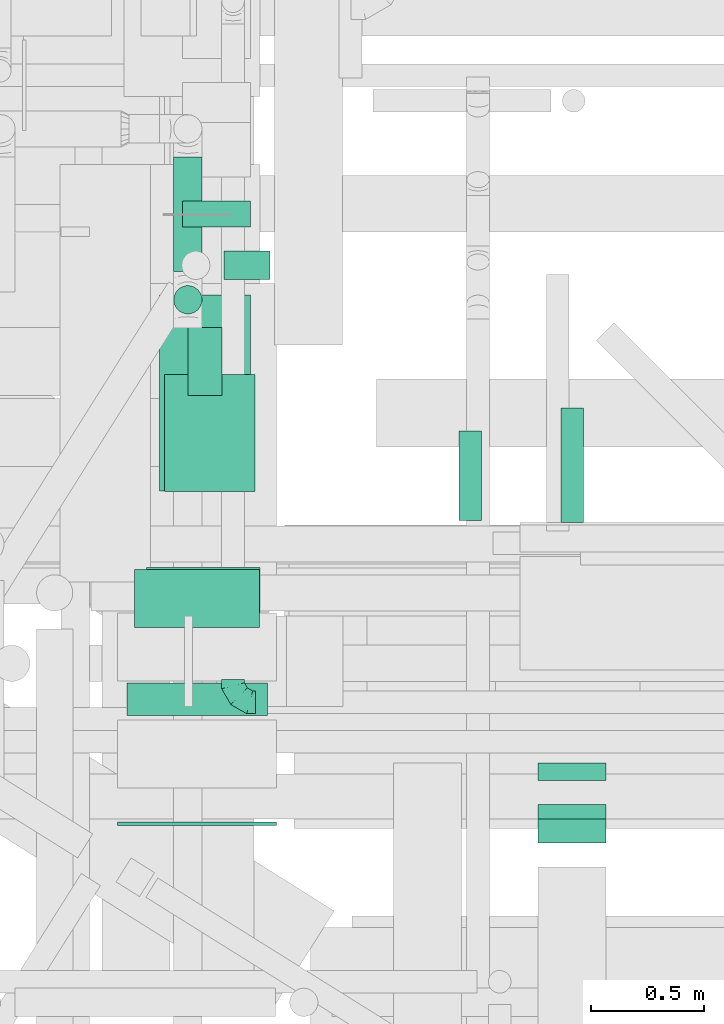
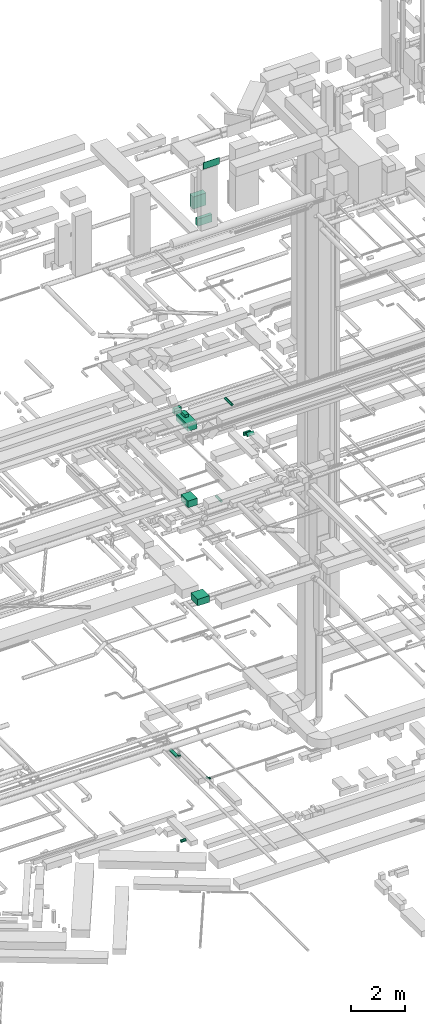
# One storey, part 104 of 337: 15 flow segments, 1 flow fitting.
"""IFC2X3 building model written with IfcOpenShell, lengths in millimetres."""

from ifc_helpers import new_model, entity, si_unit, converted_unit, derived_unit, direction, frame, origin, origin_2d_with_axis, place, context, subcontext, project, spatial, rectangle, circle, extrude, faceted_brep, source, transform, mapped, material, type_object, type_shapes, element, save


model = new_model("IFC2X3")

# Units and contexts
model_context = context("Model", 3, precision=0.01, world=origin(), true_north=direction((6.12303176911189e-17, 1.0)))
body_context = subcontext(model_context, "Body", "Model", "MODEL_VIEW")
ifc_project = project(units=[si_unit("LENGTHUNIT", "METRE", prefix="MILLI"), si_unit("AREAUNIT", "SQUARE_METRE"), si_unit("VOLUMEUNIT", "CUBIC_METRE"), converted_unit("PLANEANGLEUNIT", "DEGREE", entity("IfcRatioMeasure", 0.0174532925199433), si_unit("PLANEANGLEUNIT", "RADIAN"), dimensions=[0, 0, 0, 0, 0, 0, 0]), si_unit("MASSUNIT", "GRAM", prefix="KILO"), derived_unit("MASSDENSITYUNIT", [(si_unit("MASSUNIT", "GRAM", prefix="KILO"), 1), (si_unit("LENGTHUNIT", "METRE"), -3)]), derived_unit("MOMENTOFINERTIAUNIT", [(si_unit("LENGTHUNIT", "METRE"), 4)]), si_unit("TIMEUNIT", "SECOND"), si_unit("FREQUENCYUNIT", "HERTZ"), si_unit("THERMODYNAMICTEMPERATUREUNIT", "DEGREE_CELSIUS"), derived_unit("THERMALTRANSMITTANCEUNIT", [(si_unit("MASSUNIT", "GRAM", prefix="KILO"), 1), (si_unit("THERMODYNAMICTEMPERATUREUNIT", "KELVIN"), -1), (si_unit("TIMEUNIT", "SECOND"), -3)]), derived_unit("VOLUMETRICFLOWRATEUNIT", [(si_unit("LENGTHUNIT", "METRE"), 3), (si_unit("TIMEUNIT", "SECOND"), -1)]), derived_unit("MASSFLOWRATEUNIT", [(si_unit("MASSUNIT", "GRAM", prefix="KILO"), 1), (si_unit("TIMEUNIT", "SECOND"), -1)]), derived_unit("ROTATIONALFREQUENCYUNIT", [(si_unit("TIMEUNIT", "SECOND"), -1)]), si_unit("ELECTRICCURRENTUNIT", "AMPERE"), si_unit("ELECTRICVOLTAGEUNIT", "VOLT"), si_unit("POWERUNIT", "WATT"), si_unit("FORCEUNIT", "NEWTON", prefix="KILO"), si_unit("ILLUMINANCEUNIT", "LUX"), si_unit("LUMINOUSFLUXUNIT", "LUMEN"), si_unit("LUMINOUSINTENSITYUNIT", "CANDELA"), derived_unit("USERDEFINED", [(si_unit("MASSUNIT", "GRAM", prefix="KILO"), -1), (si_unit("LENGTHUNIT", "METRE"), -2), (si_unit("TIMEUNIT", "SECOND"), 3), (si_unit("LUMINOUSFLUXUNIT", "LUMEN"), 1)]), derived_unit("LINEARVELOCITYUNIT", [(si_unit("LENGTHUNIT", "METRE"), 1), (si_unit("TIMEUNIT", "SECOND"), -1)]), si_unit("PRESSUREUNIT", "PASCAL"), derived_unit("USERDEFINED", [(si_unit("LENGTHUNIT", "METRE"), -2), (si_unit("MASSUNIT", "GRAM", prefix="KILO"), 1), (si_unit("TIMEUNIT", "SECOND"), -2)]), derived_unit("LINEARFORCEUNIT", [(si_unit("MASSUNIT", "GRAM", prefix="KILO"), 1), (si_unit("LENGTHUNIT", "METRE"), 1), (si_unit("TIMEUNIT", "SECOND"), -2), (si_unit("LENGTHUNIT", "METRE"), -1)]), derived_unit("PLANARFORCEUNIT", [(si_unit("MASSUNIT", "GRAM", prefix="KILO"), 1), (si_unit("LENGTHUNIT", "METRE"), 1), (si_unit("TIMEUNIT", "SECOND"), -2), (si_unit("LENGTHUNIT", "METRE"), -2)])], contexts=[model_context])

# Site, building, storey
site_placement = place(None, origin())
site = spatial("IfcSite", under=ifc_project, at=site_placement, CompositionType="ELEMENT")
building_placement = place(site_placement, origin())
building = spatial("IfcBuilding", under=site, at=building_placement, CompositionType="ELEMENT")
storey_placement = place(building_placement, origin())
storey = spatial("IfcBuildingStorey", under=building, at=storey_placement, CompositionType="ELEMENT", Elevation=0.0)

# Flow segments
duct_segment_type_1 = type_object("IfcDuctSegmentType", PredefinedType="NOTDEFINED")
flow_segment_1_placement = place(storey_placement, frame((18241.81, 9637.88, 11250.0)))
element("IfcFlowSegment", 1, at=flow_segment_1_placement, inside=storey, type_object=duct_segment_type_1, context=body_context, shape_type="SweptSolid", body=[
    extrude(rectangle(XDim=499.999999999994, YDim=500.000000000001, at=origin_2d_with_axis()), frame((250.0, 250.0, 0.0), z_axis=(0.0, 0.0, 1.0), x_axis=(0.0, 1.0, 0.0)), (0.0, 0.0, 1.0), 300.000000000001),
])
flow_segment_2_placement = place(storey_placement, frame((18320.0, 10474.94, 15150.0)))
element("IfcFlowSegment", 2, at=flow_segment_2_placement, inside=storey, type_object=duct_segment_type_1, context=body_context, shape_type="SweptSolid", body=[
    extrude(rectangle(XDim=515.466473710752, YDim=400.0, at=origin_2d_with_axis()), frame((200.0, 257.73, 0.0), z_axis=(0.0, 0.0, 1.0), x_axis=(0.0, 1.0, 0.0)), (0.0, 0.0, 1.0), 300.000000000001),
])
flow_segment_3_placement = place(storey_placement, frame((18299.92, 10475.3, 18600.0)))
element("IfcFlowSegment", 3, at=flow_segment_3_placement, inside=storey, type_object=duct_segment_type_1, context=body_context, shape_type="SweptSolid", body=[
    extrude(rectangle(XDim=865.546875000198, YDim=400.0, at=origin_2d_with_axis()), frame((200.0, 432.77, 0.0), z_axis=(0.0, 0.0, 1.0), x_axis=(0.0, 1.0, 0.0)), (0.0, 0.0, 1.0), 300.000000000001),
])
flow_segment_4_placement = place(storey_placement, frame((19970.04, 9198.82, 18580.0)))
element("IfcFlowSegment", 4, at=flow_segment_4_placement, inside=storey, type_object=duct_segment_type_1, context=body_context, shape_type="SweptSolid", body=[
    extrude(rectangle(XDim=76.7860267779954, YDim=300.000000000001, at=origin_2d_with_axis()), frame((150.0, 38.39, 0.0), z_axis=(0.0, 0.0, 1.0), x_axis=(0.0, -1.0, 0.0)), (0.0, 0.0, 1.0), 150.000000000001),
])
flow_segment_5_placement = place(storey_placement, frame((19970.04, 8923.49, 18667.87)))
element("IfcFlowSegment", 5, at=flow_segment_5_placement, inside=storey, type_object=duct_segment_type_1, context=body_context, shape_type="SweptSolid", body=[
    extrude(rectangle(XDim=89.3755415948961, YDim=149.999999999998, at=origin_2d_with_axis()), frame((0.0, 84.63, 84.63), z_axis=(1.0, 0.0, 0.0), x_axis=(0.0, -0.707106781186439, 0.707106781186657)), (0.0, 0.0, 1.0), 300.000000000001),
])
flow_segment_6_placement = place(storey_placement, frame((18399.92, 11640.84, 18625.0)))
element("IfcFlowSegment", 6, at=flow_segment_6_placement, inside=storey, type_object=duct_segment_type_1, context=body_context, shape_type="SweptSolid", body=[
    extrude(rectangle(XDim=115.778770347195, YDim=299.999999999999, at=origin_2d_with_axis()), frame((150.0, 57.89, 0.0), z_axis=(0.0, 0.0, 1.0), x_axis=(0.0, 1.0, 0.0)), (0.0, 0.0, 1.0), 249.999999999999),
])
flow_segment_7_placement = place(storey_placement, frame((18425.31, 10896.76, 18920.0)))
element("IfcFlowSegment", 7, at=flow_segment_7_placement, inside=storey, type_object=duct_segment_type_1, context=body_context, shape_type="SweptSolid", body=[
    extrude(rectangle(XDim=300.000000000001, YDim=150.000000000001, at=origin_2d_with_axis()), frame((75.0, 150.0, 0.0), z_axis=(0.0, 0.0, 1.0), x_axis=(0.0, -1.0, 0.0)), (0.0, 0.0, 1.0), 129.999999999996),
])
flow_segment_8_placement = place(storey_placement, frame((18189.38, 9874.6, 29039.0)))
element("IfcFlowSegment", 8, at=flow_segment_8_placement, inside=storey, type_object=duct_segment_type_1, context=body_context, shape_type="SweptSolid", body=[
    extrude(rectangle(XDim=255.000000000001, YDim=550.000000000001, at=origin_2d_with_axis()), frame((275.0, 127.5, 0.0), z_axis=(0.0, 0.0, 1.0), x_axis=(0.0, -1.0, 0.0)), (0.0, 0.0, 1.0), 549.999999999996),
])
flow_segment_9_placement = place(storey_placement, frame((18154.38, 9486.27, 28512.0)))
element("IfcFlowSegment", 9, at=flow_segment_9_placement, inside=storey, type_object=duct_segment_type_1, context=body_context, shape_type="SweptSolid", body=[
    extrude(rectangle(XDim=143.3773843962, YDim=620.0, at=origin_2d_with_axis()), frame((310.0, 71.69, 0.0), z_axis=(0.0, 0.0, 1.0), x_axis=(0.0, -1.0, 0.0)), (0.0, 0.0, 1.0), 330.000000000003),
])
duct_segment_type_2 = type_object("IfcDuctSegmentType", PredefinedType="NOTDEFINED")
flow_segment_10_placement = place(storey_placement, frame((18584.05, 11408.12, -664.1)))
element("IfcFlowSegment", 10, at=flow_segment_10_placement, inside=storey, type_object=duct_segment_type_2, context=body_context, shape_type="SweptSolid", body=[
    extrude(circle(Radius=62.5, at=origin_2d_with_axis()), frame((0.0, 64.1, 64.1), z_axis=(1.0, 0.0, 0.0), x_axis=(0.0, 1.0, 0.0)), (0.0, 0.0, 1.0), 201.490178521172),
])
flow_segment_11_placement = place(storey_placement, frame((18360.0, 11445.08, 3225.9)))
element("IfcFlowSegment", 11, at=flow_segment_11_placement, inside=storey, type_object=duct_segment_type_2, context=body_context, shape_type="SweptSolid", body=[
    extrude(circle(Radius=62.5, at=origin_2d_with_axis()), frame((64.1, 0.0, 64.1), z_axis=(0.0, 1.0, 0.0), x_axis=(-1.0, 0.0, 0.0)), (0.0, 0.0, 1.0), 504.460969082676),
])
flow_segment_12_placement = place(storey_placement, frame((18360.0, 11255.98, 3415.0)))
element("IfcFlowSegment", 12, at=flow_segment_12_placement, inside=storey, type_object=duct_segment_type_2, context=body_context, shape_type="SweptSolid", body=[
    extrude(circle(Radius=62.5, at=origin_2d_with_axis()), frame((64.1, 64.1, 0.0)), (0.0, 0.0, 1.0), 60.0000000000145),
])
flow_segment_13_placement = place(storey_placement, frame((20068.29, 10337.4, 19198.4)))
element("IfcFlowSegment", 13, at=flow_segment_13_placement, inside=storey, type_object=duct_segment_type_2, context=body_context, shape_type="SweptSolid", body=[
    extrude(circle(Radius=50.0, at=origin_2d_with_axis()), frame((51.6, 0.0, 51.6), z_axis=(0.0, 1.0, 0.0), x_axis=(1.0, 0.0, 0.0)), (0.0, 0.0, 1.0), 504.999857237996),
])
flow_segment_14_placement = place(storey_placement, frame((19618.43, 10346.29, 14998.4)))
element("IfcFlowSegment", 14, at=flow_segment_14_placement, inside=storey, type_object=duct_segment_type_2, context=body_context, shape_type="SweptSolid", body=[
    extrude(circle(Radius=50.0, at=origin_2d_with_axis()), frame((51.6, 0.0, 51.6), z_axis=(0.0, 1.0, 0.0), x_axis=(1.0, 0.0, 0.0)), (0.0, 0.0, 1.0), 394.049708258769),
])
duct_segment_type_3 = type_object("IfcDuctSegmentType", PredefinedType="NOTDEFINED")
flow_segment_15_placement = place(storey_placement, frame((18114.38, 8999.6, 31400.0)))
element("IfcFlowSegment", 15, at=flow_segment_15_placement, inside=storey, type_object=duct_segment_type_3, context=body_context, shape_type="SweptSolid", body=[
    extrude(rectangle(XDim=16.6716282640339, YDim=699.999999999999, at=origin_2d_with_axis()), frame((350.0, 8.34, 0.0), z_axis=(0.0, 0.0, 1.0), x_axis=(0.0, -1.0, 0.0)), (0.0, 0.0, 1.0), 300.000000000001),
])

# Flow fitting
ifc_material = material()
duct_fitting_type = type_object("IfcDuctFittingType", PredefinedType="NOTDEFINED", material=ifc_material)
shared_shape = source(origin(), body_context, "Body", "Brep", [
    faceted_brep([(-100.0, 0.0, -50.0), (-100.0, -12.94, -48.3), (-100.0, -25.0, -43.3), (-100.0, -35.36, -35.36), (-100.0, -43.3, -25.0), (-100.0, -48.3, -12.94), (-100.0, -50.0, 0.0), (-100.0, -48.3, 12.94), (-100.0, -43.3, 25.0), (-100.0, -35.36, 35.36), (-100.0, -25.0, 43.3), (-100.0, -12.94, 48.3), (-100.0, 0.0, 50.0), (-100.0, 12.94, 48.3), (-100.0, 25.0, 43.3), (-100.0, 35.36, 35.36), (-100.0, 43.3, 25.0), (-100.0, 48.3, 12.94), (-100.0, 50.0, 0.0), (-100.0, 48.3, -12.94), (-100.0, 43.3, -25.0), (-100.0, 35.36, -35.36), (-100.0, 25.0, -43.3), (-100.0, 12.94, -48.3), (-76.67, 12.94, 48.3), (-79.9, 25.0, 43.3), (-73.21, 0.0, 50.0), (-82.68, 35.36, 35.36), (-86.15, 48.3, 12.94), (-86.6, 50.0, 0.0), (-84.81, 43.3, 25.0), (-84.81, 43.3, -25.0), (-82.68, 35.36, -35.36), (-86.15, 48.3, -12.94), (-76.67, 12.94, -48.3), (-73.21, 0.0, -50.0), (-79.9, 25.0, -43.3), (-69.74, -12.94, -48.3), (-66.51, -25.0, -43.3), (-63.73, -35.36, -35.36), (-61.6, -43.3, -25.0), (-60.26, -48.3, -12.94), (-59.81, -50.0, 0.0), (-60.26, -48.3, 12.94), (-61.6, -43.3, 25.0), (-63.73, -35.36, 35.36), (-66.51, -25.0, 43.3), (-69.74, -12.94, 48.3), (-36.27, 36.27, 48.3), (-45.1, 45.1, 43.3), (-26.79, 26.79, 50.0), (-52.68, 52.68, 35.36), (-58.49, 58.49, 25.0), (-62.15, 62.15, 12.94), (-63.4, 63.4, 0.0), (-62.15, 62.15, -12.94), (-58.49, 58.49, -25.0), (-52.68, 52.68, -35.36), (-36.27, 36.27, -48.3), (-26.79, 26.79, -50.0), (-45.1, 45.1, -43.3), (-17.32, 17.32, -48.3), (-8.49, 8.49, -43.3), (-0.91, 0.91, -35.36), (4.9, -4.9, -25.0), (8.56, -8.56, -12.94), (9.81, -9.81, 0.0), (8.56, -8.56, 12.94), (4.9, -4.9, 25.0), (-0.91, 0.91, 35.36), (-8.49, 8.49, 43.3), (-17.32, 17.32, 48.3), (-12.94, 76.67, 48.3), (-25.0, 79.9, 43.3), (0.0, 73.21, 50.0), (-35.36, 82.68, 35.36), (-43.3, 84.81, 25.0), (-48.3, 86.15, 12.94), (-50.0, 86.6, 0.0), (-48.3, 86.15, -12.94), (-43.3, 84.81, -25.0), (-35.36, 82.68, -35.36), (-12.94, 76.67, -48.3), (0.0, 73.21, -50.0), (-25.0, 79.9, -43.3), (12.94, 69.74, -48.3), (25.0, 66.51, -43.3), (35.36, 63.73, -35.36), (43.3, 61.6, -25.0), (48.3, 60.26, -12.94), (50.0, 59.81, 0.0), (48.3, 60.26, 12.94), (43.3, 61.6, 25.0), (35.36, 63.73, 35.36), (25.0, 66.51, 43.3), (12.94, 69.74, 48.3), (-12.94, 100.0, -48.3), (-25.0, 100.0, -43.3), (-35.36, 100.0, -35.36), (-43.3, 100.0, -25.0), (-48.3, 100.0, -12.94), (-50.0, 100.0, 0.0), (-48.3, 100.0, 12.94), (-43.3, 100.0, 25.0), (-35.36, 100.0, 35.36), (-25.0, 100.0, 43.3), (-12.94, 100.0, 48.3), (0.0, 100.0, 50.0), (12.94, 100.0, 48.3), (25.0, 100.0, 43.3), (35.36, 100.0, 35.36), (43.3, 100.0, 25.0), (48.3, 100.0, 12.94), (50.0, 100.0, 0.0), (48.3, 100.0, -12.94), (43.3, 100.0, -25.0), (35.36, 100.0, -35.36), (25.0, 100.0, -43.3), (12.94, 100.0, -48.3), (0.0, 100.0, -50.0)], [[[0, 1, 2, 3, 4, 5, 6, 7, 8, 9, 10, 11, 12, 13, 14, 15, 16, 17, 18, 19, 20, 21, 22, 23]], [[24, 25, 14, 13]], [[26, 24, 13, 12]], [[14, 25, 27, 15]], [[28, 29, 18, 17]], [[30, 28, 17, 16]], [[15, 27, 30, 16]], [[20, 31, 32, 21]], [[33, 31, 20, 19]], [[18, 29, 33, 19]], [[34, 35, 0, 23]], [[36, 34, 23, 22]], [[32, 36, 22, 21]], [[2, 1, 37, 38]], [[3, 2, 38, 39]], [[0, 35, 37, 1]], [[5, 4, 40, 41]], [[6, 5, 41, 42]], [[3, 39, 40, 4]], [[6, 42, 43, 7]], [[7, 43, 44, 8]], [[8, 44, 45, 9]], [[10, 46, 47, 11]], [[11, 47, 26, 12]], [[10, 9, 45, 46]], [[48, 49, 25, 24]], [[50, 48, 24, 26]], [[27, 25, 49, 51]], [[52, 53, 28, 30]], [[51, 52, 30, 27]], [[29, 28, 53, 54]], [[55, 56, 31, 33]], [[54, 55, 33, 29]], [[57, 32, 31, 56]], [[58, 59, 35, 34]], [[60, 58, 34, 36]], [[57, 60, 36, 32]], [[37, 35, 59, 61]], [[38, 37, 61, 62]], [[39, 38, 62, 63]], [[41, 40, 64, 65]], [[42, 41, 65, 66]], [[63, 64, 40, 39]], [[43, 42, 66, 67]], [[44, 43, 67, 68]], [[68, 69, 45, 44]], [[46, 45, 69, 70]], [[47, 46, 70, 71]], [[26, 47, 71, 50]], [[72, 73, 49, 48]], [[74, 72, 48, 50]], [[51, 49, 73, 75]], [[76, 77, 53, 52]], [[75, 76, 52, 51]], [[54, 53, 77, 78]], [[79, 80, 56, 55]], [[78, 79, 55, 54]], [[81, 57, 56, 80]], [[82, 83, 59, 58]], [[84, 82, 58, 60]], [[81, 84, 60, 57]], [[61, 59, 83, 85]], [[62, 61, 85, 86]], [[63, 62, 86, 87]], [[65, 64, 88, 89]], [[66, 65, 89, 90]], [[87, 88, 64, 63]], [[67, 66, 90, 91]], [[68, 67, 91, 92]], [[92, 93, 69, 68]], [[70, 69, 93, 94]], [[71, 70, 94, 95]], [[50, 71, 95, 74]], [[96, 97, 98, 99, 100, 101, 102, 103, 104, 105, 106, 107, 108, 109, 110, 111, 112, 113, 114, 115, 116, 117, 118, 119]], [[72, 74, 107, 106]], [[73, 72, 106, 105]], [[75, 73, 105, 104]], [[77, 76, 103, 102]], [[78, 77, 102, 101]], [[75, 104, 103, 76]], [[78, 101, 100, 79]], [[79, 100, 99, 80]], [[80, 99, 98, 81]], [[96, 119, 83, 82]], [[97, 96, 82, 84]], [[84, 81, 98, 97]], [[83, 119, 118, 85]], [[85, 118, 117, 86]], [[86, 117, 116, 87]], [[88, 115, 114, 89]], [[89, 114, 113, 90]], [[87, 116, 115, 88]], [[91, 90, 113, 112]], [[92, 91, 112, 111]], [[93, 92, 111, 110]], [[95, 94, 109, 108]], [[74, 95, 108, 107]], [[110, 109, 94, 93]]]),
])
type_shapes(duct_fitting_type, [shared_shape])
flow_fitting_placement = place(storey_placement, frame((18623.44, 9543.58, 3380.0), z_axis=(0.0, 0.0, 1.0), x_axis=(0.0, -1.0, 0.0)))
element("IfcFlowFitting", 16, at=flow_fitting_placement, inside=storey, type_object=duct_fitting_type, material=ifc_material, context=body_context, shape_type="MappedRepresentation", body=[
    mapped(shared_shape, transform((0.0, 0.0, 0.0), scale=1.0)),
])

save(model, "model.ifc")
